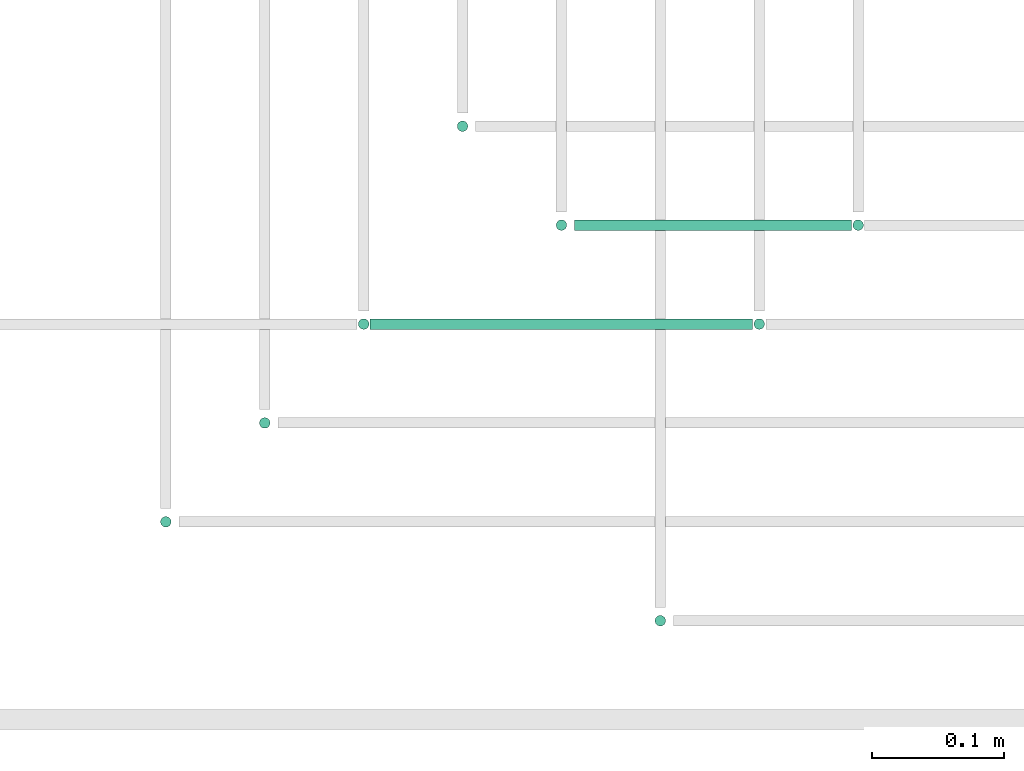
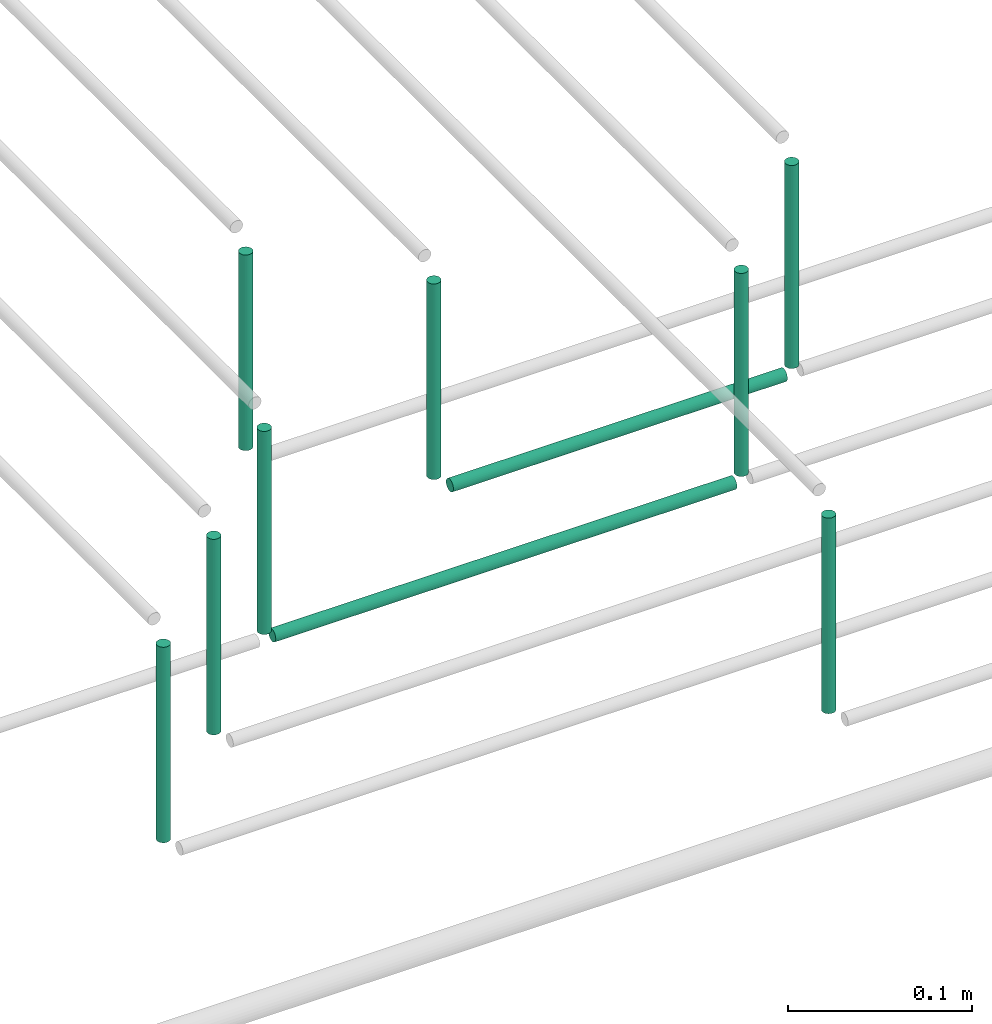
# One storey, part 41 of 89: 10 flow segments.
"""IFC2X3 building model written with IfcOpenShell, lengths in millimetres."""

from ifc_helpers import new_model, entity, si_unit, converted_unit, derived_unit, direction, frame, origin, origin_2d_with_axis, place, context, subcontext, project, spatial, circle, extrude, type_object, element, save


model = new_model("IFC2X3")

# Units and contexts
model_context = context("Model", 3, precision=0.01, world=origin(), true_north=direction((6.12303176911189e-17, 1.0)))
body_context = subcontext(model_context, "Body", "Model", "MODEL_VIEW")
ifc_project = project(units=[si_unit("LENGTHUNIT", "METRE", prefix="MILLI"), si_unit("AREAUNIT", "SQUARE_METRE"), si_unit("VOLUMEUNIT", "CUBIC_METRE"), converted_unit("PLANEANGLEUNIT", "DEGREE", entity("IfcRatioMeasure", 0.0174532925199433), si_unit("PLANEANGLEUNIT", "RADIAN"), dimensions=[0, 0, 0, 0, 0, 0, 0]), si_unit("MASSUNIT", "GRAM", prefix="KILO"), derived_unit("MASSDENSITYUNIT", [(si_unit("MASSUNIT", "GRAM", prefix="KILO"), 1), (si_unit("LENGTHUNIT", "METRE"), -3)]), derived_unit("MOMENTOFINERTIAUNIT", [(si_unit("LENGTHUNIT", "METRE"), 4)]), si_unit("TIMEUNIT", "SECOND"), si_unit("FREQUENCYUNIT", "HERTZ"), si_unit("THERMODYNAMICTEMPERATUREUNIT", "DEGREE_CELSIUS"), derived_unit("THERMALTRANSMITTANCEUNIT", [(si_unit("MASSUNIT", "GRAM", prefix="KILO"), 1), (si_unit("THERMODYNAMICTEMPERATUREUNIT", "KELVIN"), -1), (si_unit("TIMEUNIT", "SECOND"), -3)]), derived_unit("VOLUMETRICFLOWRATEUNIT", [(si_unit("LENGTHUNIT", "METRE"), 3), (si_unit("TIMEUNIT", "SECOND"), -1)]), derived_unit("MASSFLOWRATEUNIT", [(si_unit("MASSUNIT", "GRAM", prefix="KILO"), 1), (si_unit("TIMEUNIT", "SECOND"), -1)]), derived_unit("ROTATIONALFREQUENCYUNIT", [(si_unit("TIMEUNIT", "SECOND"), -1)]), si_unit("ELECTRICCURRENTUNIT", "AMPERE"), si_unit("ELECTRICVOLTAGEUNIT", "VOLT"), si_unit("POWERUNIT", "WATT"), si_unit("FORCEUNIT", "NEWTON", prefix="KILO"), si_unit("ILLUMINANCEUNIT", "LUX"), si_unit("LUMINOUSFLUXUNIT", "LUMEN"), si_unit("LUMINOUSINTENSITYUNIT", "CANDELA"), derived_unit("USERDEFINED", [(si_unit("MASSUNIT", "GRAM", prefix="KILO"), -1), (si_unit("LENGTHUNIT", "METRE"), -2), (si_unit("TIMEUNIT", "SECOND"), 3), (si_unit("LUMINOUSFLUXUNIT", "LUMEN"), 1)]), derived_unit("LINEARVELOCITYUNIT", [(si_unit("LENGTHUNIT", "METRE"), 1), (si_unit("TIMEUNIT", "SECOND"), -1)]), si_unit("PRESSUREUNIT", "PASCAL"), derived_unit("USERDEFINED", [(si_unit("LENGTHUNIT", "METRE"), -2), (si_unit("MASSUNIT", "GRAM", prefix="KILO"), 1), (si_unit("TIMEUNIT", "SECOND"), -2)]), derived_unit("LINEARFORCEUNIT", [(si_unit("MASSUNIT", "GRAM", prefix="KILO"), 1), (si_unit("LENGTHUNIT", "METRE"), 1), (si_unit("TIMEUNIT", "SECOND"), -2), (si_unit("LENGTHUNIT", "METRE"), -1)]), derived_unit("PLANARFORCEUNIT", [(si_unit("MASSUNIT", "GRAM", prefix="KILO"), 1), (si_unit("LENGTHUNIT", "METRE"), 1), (si_unit("TIMEUNIT", "SECOND"), -2), (si_unit("LENGTHUNIT", "METRE"), -2)])], contexts=[model_context])

# Site, building, storey
site_placement = place(None, frame((0.0, -0.00077364408347762, 0.0)))
site = spatial("IfcSite", under=ifc_project, at=site_placement, CompositionType="ELEMENT")
building_placement = place(site_placement, origin())
building = spatial("IfcBuilding", under=site, at=building_placement, CompositionType="ELEMENT")
storey_placement = place(building_placement, frame((0.0, 0.0, 24000.0)))
storey = spatial("IfcBuildingStorey", under=building, at=storey_placement, CompositionType="ELEMENT", Elevation=24000.0)

# Flow segments
pipe_segment_type = type_object("IfcPipeSegmentType", PredefinedType="NOTDEFINED")
for number, where in (
    (1, (44495.5981151137, 1319.35602729994, 3010.0)),
    (2, (44570.5981151137, 1394.35602729991, 3010.0)),
):
    element("IfcFlowSegment", number, at=place(storey_placement, frame(where)), inside=storey, type_object=pipe_segment_type, context=body_context, shape_type="SweptSolid", body=[
        extrude(circle(Radius=4.0, at=origin_2d_with_axis()), frame((5.59527223591499, 5.5952722359158, 0.0)), (0.0, 0.0, 1.0), 130.000000000005),
    ])
flow_segment_1_placement = place(storey_placement, frame((44645.5981151137, 1469.35602729994, 3005.0)))
element("IfcFlowSegment", 3, at=flow_segment_1_placement, inside=storey, type_object=pipe_segment_type, context=body_context, shape_type="SweptSolid", body=[
    extrude(circle(Radius=4.0, at=origin_2d_with_axis()), frame((5.59527223591499, 5.5952722359158, 0.0), z_axis=(0.0, 0.0, 1.0), x_axis=(-1.0, 0.0, 0.0)), (0.0, 0.0, 1.0), 134.999999999987),
])
flow_segment_2_placement = place(storey_placement, frame((44656.1933873496, 1469.35602729994, 2994.4047277641)))
element("IfcFlowSegment", 4, at=flow_segment_2_placement, inside=storey, type_object=pipe_segment_type, context=body_context, shape_type="SweptSolid", body=[
    extrude(circle(Radius=4.0, at=origin_2d_with_axis()), frame((0.0, 5.5952722359158, 5.59527223591499), z_axis=(1.0, 0.0, 0.0), x_axis=(0.0, 1.0, 0.0)), (0.0, 0.0, 1.0), 289.999999999995),
])
for number, where in (
    (5, (44720.5981151137, 1619.35602729996, 3010.0)),
    (6, (44795.5981151137, 1544.35602729992, 3010.0)),
):
    element("IfcFlowSegment", number, at=place(storey_placement, frame(where)), inside=storey, type_object=pipe_segment_type, context=body_context, shape_type="SweptSolid", body=[
        extrude(circle(Radius=4.0, at=origin_2d_with_axis()), frame((5.59527223591499, 5.5952722359158, 0.0)), (0.0, 0.0, 1.0), 130.000000000005),
    ])
flow_segment_3_placement = place(storey_placement, frame((44870.5982478344, 1244.35602729991, 3010.0)))
element("IfcFlowSegment", 7, at=flow_segment_3_placement, inside=storey, type_object=pipe_segment_type, context=body_context, shape_type="SweptSolid", body=[
    extrude(circle(Radius=4.0, at=origin_2d_with_axis()), frame((5.59527223591499, 5.5952722359158, 0.0)), (0.0, 0.0, 1.0), 129.999999999996),
])
flow_segment_4_placement = place(storey_placement, frame((45020.5981151137, 1544.35602729992, 3005.0)))
element("IfcFlowSegment", 8, at=flow_segment_4_placement, inside=storey, type_object=pipe_segment_type, context=body_context, shape_type="SweptSolid", body=[
    extrude(circle(Radius=4.0, at=origin_2d_with_axis()), frame((5.59527223591499, 5.5952722359158, 0.0), z_axis=(0.0, 0.0, 1.0), x_axis=(-1.0, 0.0, 0.0)), (0.0, 0.0, 1.0), 134.999999999995),
])
flow_segment_5_placement = place(storey_placement, frame((44811.1933873496, 1544.35602729992, 2994.40472776408)))
element("IfcFlowSegment", 9, at=flow_segment_5_placement, inside=storey, type_object=pipe_segment_type, context=body_context, shape_type="SweptSolid", body=[
    extrude(circle(Radius=4.0, at=origin_2d_with_axis()), frame((0.0, 5.5952722359158, 5.59527223591499), z_axis=(1.0, 0.0, 0.0), x_axis=(0.0, -1.0, 0.0)), (0.0, 0.0, 1.0), 209.999999999996),
])
flow_segment_6_placement = place(storey_placement, frame((44945.5981151137, 1469.35602729994, 3005.0)))
element("IfcFlowSegment", 10, at=flow_segment_6_placement, inside=storey, type_object=pipe_segment_type, context=body_context, shape_type="SweptSolid", body=[
    extrude(circle(Radius=4.0, at=origin_2d_with_axis()), frame((5.59527223591499, 5.5952722359158, 0.0), z_axis=(0.0, 0.0, 1.0), x_axis=(-1.0, 0.0, 0.0)), (0.0, 0.0, 1.0), 134.999999999987),
])

save(model, "model.ifc")
